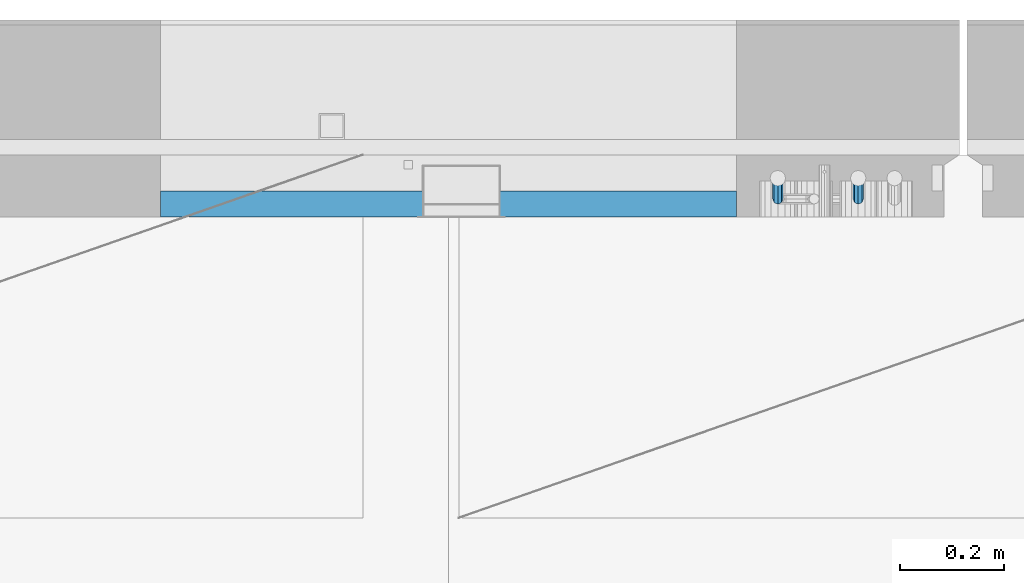
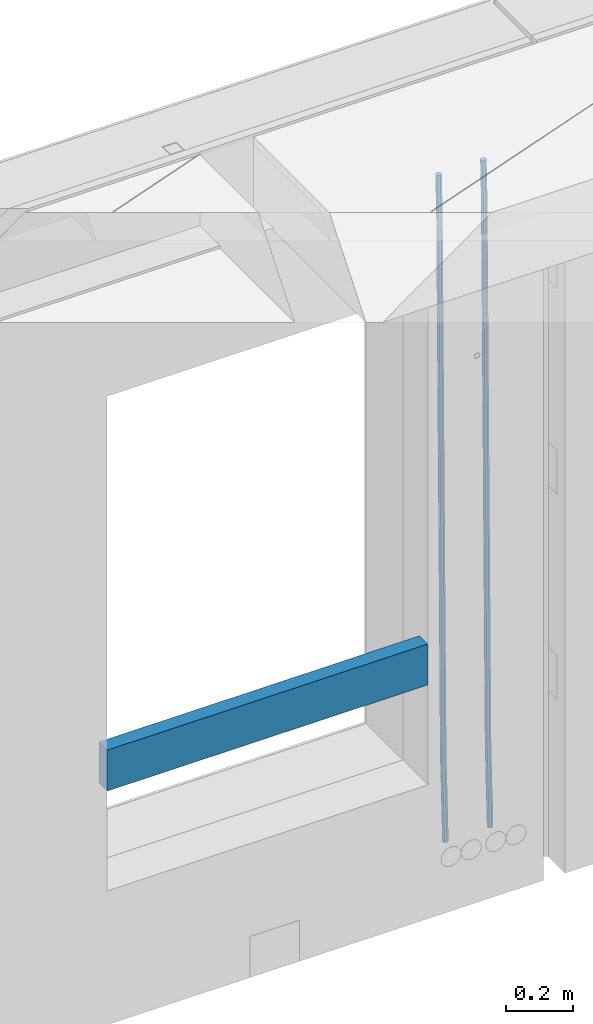
# One storey, part 100 of 309: 3 beams, 1 element without a shape of its own.
"""IFC2X3 building model written with IfcOpenShell, lengths in millimetres."""

from ifc_helpers import new_model, si_unit, frame, origin_with_axes, place, context, subcontext, project, spatial, faceted_brep, material, type_object, element, aggregate, save


model = new_model("IFC2X3")

# Units and contexts
model_context = context("Model", 3, precision=1e-05, world=origin_with_axes())
body_context = subcontext(model_context, "Body", "Model", "MODEL_VIEW")
ifc_project = project(units=[si_unit("LENGTHUNIT", "METRE", prefix="MILLI"), si_unit("AREAUNIT", "SQUARE_METRE"), si_unit("VOLUMEUNIT", "CUBIC_METRE"), si_unit("MASSUNIT", "GRAM", prefix="KILO"), si_unit("TIMEUNIT", "SECOND"), si_unit("PLANEANGLEUNIT", "RADIAN"), si_unit("SOLIDANGLEUNIT", "STERADIAN"), si_unit("THERMODYNAMICTEMPERATUREUNIT", "DEGREE_CELSIUS"), si_unit("LUMINOUSINTENSITYUNIT", "LUMEN")], contexts=[model_context])

# Site, building, storey
site_placement = place(None, origin_with_axes())
site = spatial("IfcSite", under=ifc_project, at=site_placement, CompositionType="ELEMENT")
building_placement = place(site_placement, origin_with_axes())
building = spatial("IfcBuilding", under=site, at=building_placement, CompositionType="ELEMENT")
storey_placement = place(building_placement, origin_with_axes())
storey = spatial("IfcBuildingStorey", under=building, at=storey_placement, Name="7", CompositionType="ELEMENT", Elevation=0.0)

# Assembly, beams
assembly_placement = place(storey_placement, origin_with_axes())
assembly = element("IfcElementAssembly", 1, at=assembly_placement, inside=storey, AssemblyPlace="NOTDEFINED", PredefinedType="REINFORCEMENT_UNIT")
ifc_material_1 = material()
beam_type_1 = type_object("IfcBeamType", Name="D20", PredefinedType="NOTDEFINED")
beam_1_placement = place(assembly_placement, frame((13975.1300000039, 22654.999995444, 99989.68), z_axis=(-0.000205762999925498, 0.999642804629538, -0.0267249099901004), x_axis=(4.30000201928125e-08, 0.0267249099948059, 0.999642825806181)))
beam_1 = element("IfcBeam", 2, at=beam_1_placement, type_object=beam_type_1, material=ifc_material_1, Name="JM20", ObjectType="D20", context=body_context, shape_type="Brep", body=[
    faceted_brep([(0.0, -10.0, 0.0), (-4.19531716033816e-08, -7.07106781186667, -7.07106781187031), (60.4266690400545, -7.0710677960451, -7.07106780570757), (60.4266690441291, -9.99999998418934, 6.15546014159918e-09), (0.0, 0.0, -10.0), (60.426669036824, 1.58106558956206e-08, -9.99999999384454), (4.196772351861e-08, 7.07106781186303, -7.07106781186667), (60.4266690363438, 7.07106782768096, -7.07106780570757), (0.0, 10.0, 0.0), (60.4266690388904, 10.0000000158179, 6.15182216279209e-09), (4.196772351861e-08, 7.07106781185939, 7.07106781185939), (60.4266690429649, 7.07106782768096, 7.07106781802577), (0.0, 0.0, 10.0), (60.4266690461809, 1.58179318532348e-08, 10.0000000061555), (-4.19531716033816e-08, -7.07106781187031, 7.07106781185939), (60.4266690466611, -7.07106779605238, 7.07106781802213), (61.0378400410118, -7.07106779588503, -7.07106780564936), (60.991799419251, -9.99999998403655, 6.21366780251265e-09), (61.0569027789461, 1.5985278878361e-08, -9.99999999378269), (61.0378209396877, 7.07106782784831, -7.07106780564936), (60.9917724058905, 10.0000000159635, 6.21366780251265e-09), (60.9457317841297, 7.07106782781193, 7.0710678180767), (60.9266690461809, 1.59488990902901e-08, 10.0000000062028), (60.9457508854539, -7.07106779591413, 7.0710678180767), (61.6489592143771, -7.07106614513759, -7.06310863441468), (61.5568818710308, -9.9999984576425, 0.00735959856683621), (61.6870830769039, 1.71821739058942e-06, -9.99179257185824), (61.6489210170112, 7.07106947854481, -7.06310888312146), (61.556827851804, 10.0000015422847, 0.00735924683976918), (61.4647505084577, 7.07106922979438, 7.07782747982128), (61.4266266459163, 1.36643211590126e-06, 10.0065114172685), (61.464788705809, -7.07106639389531, 7.07782772852806), (176.543135720174, -7.07075579406956, -5.56673531796696), (176.451058376813, -9.99968810657447, 1.50373291501455), (176.581259582701, 0.000312069292704109, -8.49541925541052), (176.543097522794, 7.07137982961285, -5.56673556667374), (176.451004357587, 10.00031189336, 1.50373256329476), (176.35892701424, 7.07137958085514, 8.57420079627263), (176.320803151699, 0.000311717507429421, 11.5028847337162), (176.358965211621, -7.07075604281999, 8.57420104497578), (177.098753836006, -7.07075429323595, -5.55949898843028), (176.98362511232, -9.99968666800123, 1.510669025065), (177.146421932586, 0.000313595905026887, -8.48805862247536), (177.098706077581, 7.07138133041735, -5.55949936166144), (176.983557571715, 10.0003133318824, 1.51066849724157), (176.868428848029, 7.07138095712435, 8.58083651073321), (176.820760751449, 0.000313067976094317, 11.5093961447819), (176.868476606425, -7.07075466652896, 8.58083688396073), (177.654312950661, -7.07075204110879, -5.54863964998367), (177.516135294456, -9.99968450931192, 1.52107783331303), (177.711524267797, 0.000315886711177882, -8.47701274570863), (177.654255632195, 7.07138358250813, -5.54864021007961), (177.516054233929, 10.0003154905207, 1.5210770412159), (177.377876577739, 7.0713830223176, 8.59079452451624), (177.320665260588, 0.000315094497636892, 11.5191676202448), (177.377933896176, -7.07075260129932, 8.59079508461218), (299.436796249574, -7.07025836271714, -3.1681962331204), (299.298618593355, -9.99919083092027, 3.90152125031091), (299.494007566798, 0.000809565110102994, -6.09656932889993), (299.436738931283, 7.07187726089978, -3.16819679320906), (299.298537533061, 10.0008091689197, 3.90152045822106), (299.160359876842, 7.07187670072017, 10.9712379416487), (299.103148559603, 0.000808772889286047, 13.8996110374392), (299.160417195119, -7.07025892290039, 10.9712385017483), (299.98743051647, -7.07025613056248, -3.15743315966392), (299.971788958996, -9.99918809853989, 3.91467979818117), (299.993912075952, 0.000811591617093654, -6.08679785393178), (299.987423933868, 7.07187949325817, -3.1574327280432), (299.971753863239, 10.0008119014747, 3.91467990454839), (299.95611230444, 7.07187992653053, 10.9867922621015), (299.949630744944, 0.000812204350950196, 13.9161569563694), (299.956118887014, -7.07025569729012, 10.9867918304735), (300.538107039494, -7.07025785017686, -3.16575821840888), (300.644985195438, -9.99919020432935, 3.90450175465594), (300.493854948218, 0.000810030429420294, -6.09435592770024), (300.538151196495, 7.071877773491, -3.16575855385963), (300.645047642858, 10.0008097955724, 3.90450128024895), (300.751925798773, 7.07187744142357, 10.9747612533101), (300.796177890064, 0.000809560813650023, 13.9033589625978), (300.751881641787, -7.07025818224065, 10.9747615887682), (2293.36490490142, -7.07648090940347, -33.2930642912361), (2293.47178305736, -10.0054132635523, -26.2228043181785), (2293.32065281013, -0.00541302880083094, -36.2216620005347), (2293.36494905842, 7.06565471425711, -33.2930646266868), (2293.47184550477, 9.99458673634581, -26.2228047925819), (2293.57872366071, 7.06565438219332, -19.1525448195243), (2293.62297575199, -0.00541349841296324, -16.2239471102366), (2293.57867950371, -7.0764812414709, -19.1525444840736), (2294.0658245362, -7.07648309818615, -33.3036607065333), (2294.05312277409, -10.0054150789219, -26.2315929392535), (2294.10928714235, -0.00541549149056664, -36.2335844756526), (2294.15805078732, 7.06565223761572, -33.3050546393533), (2294.18355038921, 9.99458451388637, -26.2335642579346), (2294.17084862708, 7.06565253314329, -19.1614964906439), (2294.12738602093, -0.00541507354500936, -16.2315727215355), (2294.07862237596, -7.07648280265857, -19.1601025578348), (2294.76670261032, -7.08562269121467, -33.294332712383), (2294.63442802057, -10.0129954178956, -26.2238563411993), (2294.89787471293, -0.0156988342423574, -36.2230891548279), (2294.95110548967, 7.05531064255774, -33.2944998654275), (2294.89521307347, 9.98530428734011, -26.2240927312887), (2294.76293848372, 7.0579315606592, -19.1536163601049), (2294.63176638114, -0.0119922963167483, -16.2248599176673), (2294.57853560438, -7.08300177311321, -19.1534492070678), (2316.52657204497, -7.36937582653991, -33.0047303660212), (2316.39429745522, -10.2967485532172, -25.9342539948302), (2316.65774414754, -0.299451969567599, -35.9334868084661), (2316.7109749243, 6.7715575072325, -33.0048975190657), (2316.65508250811, 9.70155115201487, -25.9344903849269), (2316.52280791836, 6.7741784253376, -18.8640140137468), (2316.39163581574, -0.295745431634714, -15.9352575713092), (2316.33840503903, -7.36675490843481, -18.863846860706), (2317.16202064224, -7.37766220584308, -32.9962731735213), (2317.05438744847, -10.3053562613532, -25.9254688497131), (2317.23607125619, -0.306993473008333, -35.925789846493), (2317.23316144495, 6.76474808850253, -32.9979477328052), (2317.15499573652, 9.6950321815566, -25.9278370341635), (2317.04736254275, 6.7673381260538, -18.8570327103698), (2316.97331192881, -0.303330606784584, -15.9275160373909), (2316.97622174003, -7.37507216829545, -18.8553581510787), (2317.79752306276, -7.37578610372293, -32.9880110666527), (2317.71453320107, -10.3033876998124, -25.9168792378296), (2317.81444760226, -0.305295583297266, -35.918287695793), (2317.75539265381, 6.76628640723357, -32.9911928173897), (2317.65495180529, 9.69652304524061, -25.9213789128698), (2317.5719619436, 6.76892144914746, -18.8502470840467), (2317.55503740412, -0.301569071270933, -15.9199704549137), (2317.61409235255, -7.3731510618054, -18.847065333317), (2417.8183084176, -7.07752398473531, -31.6906369377139), (2417.73531855589, -10.0051255808248, -24.6195051088798), (2417.83523295709, -0.007033464313281, -34.6209135668432), (2417.77617800863, 7.06454852621755, -31.6938186884508), (2417.67573716014, 9.99478516423187, -24.6240047839383), (2417.59274729842, 7.06718356813872, -17.5528729551006), (2417.57582275895, -0.00330695228694822, -14.6225963259749), (2417.6348777074, -7.07488894281778, -17.5496912043673)], [[[0, 1, 2, 3]], [[1, 4, 5, 2]], [[4, 6, 7, 5]], [[6, 8, 9, 7]], [[8, 10, 11, 9]], [[10, 12, 13, 11]], [[12, 14, 15, 13]], [[14, 0, 3, 15]], [[14, 12, 10, 8, 6, 4, 1, 0]], [[3, 2, 16, 17]], [[2, 5, 18, 16]], [[5, 7, 19, 18]], [[7, 9, 20, 19]], [[9, 11, 21, 20]], [[11, 13, 22, 21]], [[13, 15, 23, 22]], [[15, 3, 17, 23]], [[17, 16, 24, 25]], [[16, 18, 26, 24]], [[18, 19, 27, 26]], [[19, 20, 28, 27]], [[20, 21, 29, 28]], [[21, 22, 30, 29]], [[22, 23, 31, 30]], [[23, 17, 25, 31]], [[25, 24, 32, 33]], [[24, 26, 34, 32]], [[26, 27, 35, 34]], [[27, 28, 36, 35]], [[28, 29, 37, 36]], [[29, 30, 38, 37]], [[30, 31, 39, 38]], [[31, 25, 33, 39]], [[33, 32, 40, 41]], [[32, 34, 42, 40]], [[34, 35, 43, 42]], [[35, 36, 44, 43]], [[36, 37, 45, 44]], [[37, 38, 46, 45]], [[38, 39, 47, 46]], [[39, 33, 41, 47]], [[41, 40, 48, 49]], [[40, 42, 50, 48]], [[42, 43, 51, 50]], [[43, 44, 52, 51]], [[44, 45, 53, 52]], [[45, 46, 54, 53]], [[46, 47, 55, 54]], [[47, 41, 49, 55]], [[49, 48, 56, 57]], [[48, 50, 58, 56]], [[50, 51, 59, 58]], [[51, 52, 60, 59]], [[52, 53, 61, 60]], [[53, 54, 62, 61]], [[54, 55, 63, 62]], [[55, 49, 57, 63]], [[57, 56, 64, 65]], [[56, 58, 66, 64]], [[58, 59, 67, 66]], [[59, 60, 68, 67]], [[60, 61, 69, 68]], [[61, 62, 70, 69]], [[62, 63, 71, 70]], [[63, 57, 65, 71]], [[65, 64, 72, 73]], [[64, 66, 74, 72]], [[66, 67, 75, 74]], [[67, 68, 76, 75]], [[68, 69, 77, 76]], [[69, 70, 78, 77]], [[70, 71, 79, 78]], [[71, 65, 73, 79]], [[73, 72, 80, 81]], [[72, 74, 82, 80]], [[74, 75, 83, 82]], [[75, 76, 84, 83]], [[76, 77, 85, 84]], [[77, 78, 86, 85]], [[78, 79, 87, 86]], [[79, 73, 81, 87]], [[81, 80, 88, 89]], [[80, 82, 90, 88]], [[82, 83, 91, 90]], [[83, 84, 92, 91]], [[84, 85, 93, 92]], [[85, 86, 94, 93]], [[86, 87, 95, 94]], [[87, 81, 89, 95]], [[89, 88, 96, 97]], [[88, 90, 98, 96]], [[90, 91, 99, 98]], [[91, 92, 100, 99]], [[92, 93, 101, 100]], [[93, 94, 102, 101]], [[94, 95, 103, 102]], [[95, 89, 97, 103]], [[97, 96, 104, 105]], [[96, 98, 106, 104]], [[98, 99, 107, 106]], [[99, 100, 108, 107]], [[100, 101, 109, 108]], [[101, 102, 110, 109]], [[102, 103, 111, 110]], [[103, 97, 105, 111]], [[105, 104, 112, 113]], [[104, 106, 114, 112]], [[106, 107, 115, 114]], [[107, 108, 116, 115]], [[108, 109, 117, 116]], [[109, 110, 118, 117]], [[110, 111, 119, 118]], [[111, 105, 113, 119]], [[113, 112, 120, 121]], [[112, 114, 122, 120]], [[114, 115, 123, 122]], [[115, 116, 124, 123]], [[116, 117, 125, 124]], [[117, 118, 126, 125]], [[118, 119, 127, 126]], [[119, 113, 121, 127]], [[121, 120, 128, 129]], [[120, 122, 130, 128]], [[122, 123, 131, 130]], [[123, 124, 132, 131]], [[124, 125, 133, 132]], [[125, 126, 134, 133]], [[126, 127, 135, 134]], [[127, 121, 129, 135]], [[130, 131, 132, 133, 134, 135, 129, 128]]]),
])
beam_2_placement = place(assembly_placement, frame((14130.1300000039, 22654.999995444, 99989.68), z_axis=(-0.000205762999925498, 0.999642804629538, -0.0267249099901004), x_axis=(4.30000201928125e-08, 0.0267249099948059, 0.999642825806181)))
beam_2 = element("IfcBeam", 3, at=beam_2_placement, type_object=beam_type_1, material=ifc_material_1, Name="JM20", ObjectType="D20", context=body_context, shape_type="Brep", body=[
    faceted_brep([(0.0, -10.0, 0.0), (-4.19531716033816e-08, -7.07106781186667, -7.07106781187031), (60.3573713480873, -7.07106779909736, -7.07106780570757), (60.3573713520018, -9.99999998723251, 6.15546014159918e-09), (0.0, 0.0, -10.0), (60.357371345206, 1.27656676340848e-08, -9.99999999384454), (4.196772351861e-08, 7.07106781186303, -7.07106781186667), (60.3573713450896, 7.07106782463052, -7.07106780570757), (0.0, 10.0, 0.0), (60.3573713477817, 10.0000000127657, 6.15546014159918e-09), (4.196772351861e-08, 7.07106781185939, 7.07106781185939), (60.3573713517108, 7.07106782463234, 7.07106781802213), (0.0, 0.0, 10.0), (60.3573713545775, 1.27656676340848e-08, 10.0000000061555), (-4.19531716033816e-08, -7.07106781187031, 7.07106781185939), (60.3573713546939, -7.07106779909736, 7.07106781801849), (61.0868506554398, -7.07106779894457, -7.07106780563845), (60.991799419251, -9.99999998403655, 6.21366780251265e-09), (61.126200470535, 1.29293766804039e-08, -9.99999999376814), (61.0868120605446, 7.07106782478695, -7.07106780563481), (60.9917724058905, 10.0000000159635, 6.21366780251265e-09), (60.8967211696581, 7.07106782474875, 7.0710678180767), (60.8573713545775, 1.2872988008894e-08, 10.0000000062064), (60.8967597645533, -7.07106779898459, 7.07106781807306), (61.8160664163588, -7.07106381821541, -7.05146081959901), (61.6260258432449, -9.99999652498445, 0.017052570146916), (61.8947518331115, 4.20838841819204e-06, -9.97933536109849), (61.8159892434924, 7.07107180530511, -7.05146185687408), (61.6259167043172, 10.0000034747191, 0.0170511032192735), (61.4358761312033, 7.07107076795, 7.08556449295429), (61.3571907144506, 2.74134617939126e-06, 10.0134390344538), (61.4359533040697, -7.07106485557051, 7.08556553022936), (146.602571042196, -7.07060097563044, -4.77174073989954), (146.412530469053, -9.99953368240131, 2.29677264984275), (146.681256458905, 0.000467050971565186, -7.69961528139902), (146.602493869315, 7.07153464789008, -4.77174177717461), (146.41242133014, 10.0004663173004, 2.29677118291511), (146.222380757012, 7.07153361053315, 9.36528457265376), (146.143695340288, 0.000465583929326385, 12.2931591141532), (146.222457929893, -7.07060201298918, 9.36528560992883), (147.126399134097, -7.07059811609543, -4.75765617037177), (146.994344415885, -9.99953050632757, 2.31241632972888), (147.181075818822, 0.000469779444756568, -7.68617625315164), (147.126345609664, 7.07153750755242, -4.75765657179363), (146.994268720911, 10.0004694935578, 2.31241576203684), (146.8622140027, 7.07153710333114, 9.38248826213749), (146.807537317989, 0.000469207789137727, 12.3110083449137), (146.862267527133, -7.07059852031853, 9.38248866355571), (147.650387802729, -7.07059700935133, -4.75216798895053), (147.576336714686, -9.99952927706909, 2.3185120327762), (147.681048395651, 0.000470835462692776, -7.68093961279374), (147.650357933962, 7.07153861434745, -4.75216814260784), (147.576294473896, 10.0004707228873, 2.31851181546881), (147.502243385854, 7.07153845517132, 9.3891918371919), (147.471582792903, 0.000470610355478129, 12.3179634610351), (147.502273254577, -7.07059716852928, 9.38919199084557), (299.417920105596, -7.07027645305425, -3.16257683766162), (299.343869017583, -9.99920872077018, 3.90810318405784), (299.448580698547, 0.000791391765233129, -6.09134846150846), (299.417890236859, 7.07185917064635, -3.16257699131893), (299.343826776778, 10.0007912791862, 3.90810296676136), (299.26977568875, 7.07185901147022, 10.9787829884772), (299.239115095814, 0.000791166652561515, 13.907554612324), (299.269805557487, -7.07027661222673, 10.9787831421345), (299.955350135861, -7.07027531791755, -3.15694787336906), (299.971788958996, -9.99918809853989, 3.91467979818117), (299.94855327539, 0.000792447781350347, -6.08611182115419), (299.955357283936, 7.07186030585945, -3.15694763931606), (299.971753863239, 10.0008119014747, 3.91467990454839), (299.988192686345, 7.07186052887664, 10.9863075840512), (299.994989546802, 0.000792763177742017, 13.91547153184), (299.988185538285, -7.07027509490035, 10.9863073500019), (300.49274823608, -7.07027699627724, -3.16507219004052), (300.599626390831, -9.99920935543742, 3.90518778107071), (300.448496147656, 0.000790886399045121, -6.09366989441332), (300.492792398771, 7.07185862738334, -3.1650725155705), (300.599688846312, 10.0007906444662, 3.90518732069904), (300.706567001063, 7.07185828530783, 10.9754472918103), (300.750819089502, 0.000790402629718301, 13.9040449961867), (300.706522838373, -7.07027733835457, 10.9754476173403), (2293.36490490142, -7.07648090940347, -33.2930642912361), (2293.47178305736, -10.0054132635523, -26.2228043181785), (2293.32065281013, -0.00541302880083094, -36.2216620005347), (2293.36494905842, 7.06565471425711, -33.2930646266868), (2293.47184550477, 9.99458673634581, -26.2228047925819), (2293.57872366071, 7.06565438219332, -19.1525448195243), (2293.62297575199, -0.00541349841296324, -16.2239471102366), (2293.57867950371, -7.0764812414709, -19.1525444840736), (2294.0658245362, -7.07648309818615, -33.3036607065333), (2294.05312277409, -10.0054150789219, -26.2315929392535), (2294.10928714235, -0.00541549149056664, -36.2335844756526), (2294.15805078732, 7.06565223761572, -33.3050546393533), (2294.18355038921, 9.99458451388637, -26.2335642579346), (2294.17084862708, 7.06565253314329, -19.1614964906439), (2294.12738602093, -0.00541507354500936, -16.2315727215355), (2294.07862237596, -7.07648280265857, -19.1601025578348), (2294.76670261032, -7.08562269121467, -33.294332712383), (2294.63442802057, -10.0129954178956, -26.2238563411993), (2294.89787471293, -0.0156988342423574, -36.2230891548279), (2294.95110548967, 7.05531064255774, -33.2944998654275), (2294.89521307347, 9.98530428734011, -26.2240927312887), (2294.76293848372, 7.0579315606592, -19.1536163601049), (2294.63176638114, -0.0119922963167483, -16.2248599176673), (2294.57853560438, -7.08300177311321, -19.1534492070678), (2316.52657204497, -7.36937582653991, -33.0047303660212), (2316.39429745522, -10.2967485532172, -25.9342539948302), (2316.65774414754, -0.299451969567599, -35.9334868084661), (2316.7109749243, 6.7715575072325, -33.0048975190657), (2316.65508250811, 9.70155115201487, -25.9344903849269), (2316.52280791836, 6.7741784253376, -18.8640140137468), (2316.39163581574, -0.295745431634714, -15.9352575713092), (2316.33840503903, -7.36675490843481, -18.863846860706), (2317.16202064224, -7.37766220584308, -32.9962731735213), (2317.05438744847, -10.3053562613532, -25.9254688497131), (2317.23607125619, -0.306993473008333, -35.925789846493), (2317.23316144495, 6.76474808850253, -32.9979477328052), (2317.15499573652, 9.6950321815566, -25.9278370341635), (2317.04736254275, 6.7673381260538, -18.8570327103698), (2316.97331192881, -0.303330606784584, -15.9275160373909), (2316.97622174003, -7.37507216829545, -18.8553581510787), (2317.79752306276, -7.37578610372293, -32.9880110666527), (2317.71453320107, -10.3033876998124, -25.9168792378296), (2317.81444760226, -0.305295583297266, -35.918287695793), (2317.75539265381, 6.76628640723357, -32.9911928173897), (2317.65495180529, 9.69652304524061, -25.9213789128698), (2317.5719619436, 6.76892144914746, -18.8502470840467), (2317.55503740412, -0.301569071270933, -15.9199704549137), (2317.61409235255, -7.3731510618054, -18.847065333317), (2417.8183084176, -7.07752398473531, -31.6906369377139), (2417.73531855589, -10.0051255808248, -24.6195051088798), (2417.83523295709, -0.007033464313281, -34.6209135668432), (2417.77617800863, 7.06454852621755, -31.6938186884508), (2417.67573716014, 9.99478516423187, -24.6240047839383), (2417.59274729842, 7.06718356813872, -17.5528729551006), (2417.57582275895, -0.00330695228694822, -14.6225963259749), (2417.6348777074, -7.07488894281778, -17.5496912043673)], [[[0, 1, 2, 3]], [[1, 4, 5, 2]], [[4, 6, 7, 5]], [[6, 8, 9, 7]], [[8, 10, 11, 9]], [[10, 12, 13, 11]], [[12, 14, 15, 13]], [[14, 0, 3, 15]], [[14, 12, 10, 8, 6, 4, 1, 0]], [[3, 2, 16, 17]], [[2, 5, 18, 16]], [[5, 7, 19, 18]], [[7, 9, 20, 19]], [[9, 11, 21, 20]], [[11, 13, 22, 21]], [[13, 15, 23, 22]], [[15, 3, 17, 23]], [[17, 16, 24, 25]], [[16, 18, 26, 24]], [[18, 19, 27, 26]], [[19, 20, 28, 27]], [[20, 21, 29, 28]], [[21, 22, 30, 29]], [[22, 23, 31, 30]], [[23, 17, 25, 31]], [[25, 24, 32, 33]], [[24, 26, 34, 32]], [[26, 27, 35, 34]], [[27, 28, 36, 35]], [[28, 29, 37, 36]], [[29, 30, 38, 37]], [[30, 31, 39, 38]], [[31, 25, 33, 39]], [[33, 32, 40, 41]], [[32, 34, 42, 40]], [[34, 35, 43, 42]], [[35, 36, 44, 43]], [[36, 37, 45, 44]], [[37, 38, 46, 45]], [[38, 39, 47, 46]], [[39, 33, 41, 47]], [[41, 40, 48, 49]], [[40, 42, 50, 48]], [[42, 43, 51, 50]], [[43, 44, 52, 51]], [[44, 45, 53, 52]], [[45, 46, 54, 53]], [[46, 47, 55, 54]], [[47, 41, 49, 55]], [[49, 48, 56, 57]], [[48, 50, 58, 56]], [[50, 51, 59, 58]], [[51, 52, 60, 59]], [[52, 53, 61, 60]], [[53, 54, 62, 61]], [[54, 55, 63, 62]], [[55, 49, 57, 63]], [[57, 56, 64, 65]], [[56, 58, 66, 64]], [[58, 59, 67, 66]], [[59, 60, 68, 67]], [[60, 61, 69, 68]], [[61, 62, 70, 69]], [[62, 63, 71, 70]], [[63, 57, 65, 71]], [[65, 64, 72, 73]], [[64, 66, 74, 72]], [[66, 67, 75, 74]], [[67, 68, 76, 75]], [[68, 69, 77, 76]], [[69, 70, 78, 77]], [[70, 71, 79, 78]], [[71, 65, 73, 79]], [[73, 72, 80, 81]], [[72, 74, 82, 80]], [[74, 75, 83, 82]], [[75, 76, 84, 83]], [[76, 77, 85, 84]], [[77, 78, 86, 85]], [[78, 79, 87, 86]], [[79, 73, 81, 87]], [[81, 80, 88, 89]], [[80, 82, 90, 88]], [[82, 83, 91, 90]], [[83, 84, 92, 91]], [[84, 85, 93, 92]], [[85, 86, 94, 93]], [[86, 87, 95, 94]], [[87, 81, 89, 95]], [[89, 88, 96, 97]], [[88, 90, 98, 96]], [[90, 91, 99, 98]], [[91, 92, 100, 99]], [[92, 93, 101, 100]], [[93, 94, 102, 101]], [[94, 95, 103, 102]], [[95, 89, 97, 103]], [[97, 96, 104, 105]], [[96, 98, 106, 104]], [[98, 99, 107, 106]], [[99, 100, 108, 107]], [[100, 101, 109, 108]], [[101, 102, 110, 109]], [[102, 103, 111, 110]], [[103, 97, 105, 111]], [[105, 104, 112, 113]], [[104, 106, 114, 112]], [[106, 107, 115, 114]], [[107, 108, 116, 115]], [[108, 109, 117, 116]], [[109, 110, 118, 117]], [[110, 111, 119, 118]], [[111, 105, 113, 119]], [[113, 112, 120, 121]], [[112, 114, 122, 120]], [[114, 115, 123, 122]], [[115, 116, 124, 123]], [[116, 117, 125, 124]], [[117, 118, 126, 125]], [[118, 119, 127, 126]], [[119, 113, 121, 127]], [[121, 120, 128, 129]], [[120, 122, 130, 128]], [[122, 123, 131, 130]], [[123, 124, 132, 131]], [[124, 125, 133, 132]], [[125, 126, 134, 133]], [[126, 127, 135, 134]], [[127, 121, 129, 135]], [[130, 131, 132, 133, 134, 135, 129, 128]]]),
])
ifc_material_2 = material(Name="TIMBER/T24")
beam_type_2 = type_object("IfcBeamType", PredefinedType="NOTDEFINED")
beam_3_placement = place(assembly_placement, frame((13895.0002989913, 22644.9998418812, 100685.0), z_axis=(0.0, 0.0, 1.0), x_axis=(-1.0, 3.00000001838171e-08, 0.0)))
beam_3 = element("IfcBeam", 4, at=beam_3_placement, type_object=beam_type_2, material=ifc_material_2, context=body_context, shape_type="Brep", body=[
    faceted_brep([(-3.63797880709171e-12, 24.9999999999964, -75.0), (-3.63797880709171e-12, 24.9999999999964, 75.0), (1110.0, 24.9999999999964, 75.0), (1110.0, 24.9999999999964, -75.0), (0.0, -25.0000000000073, 75.0), (1110.0, -25.0000000000073, 75.0), (0.0, -25.0000000000073, -75.0), (1110.0, -25.0000000000073, -75.0)], [[[0, 1, 2, 3]], [[1, 4, 5, 2]], [[4, 6, 7, 5]], [[6, 0, 3, 7]], [[5, 7, 3, 2]], [[6, 4, 1, 0]]]),
])
aggregate(assembly, [beam_1, beam_2, beam_3])

save(model, "model.ifc")
